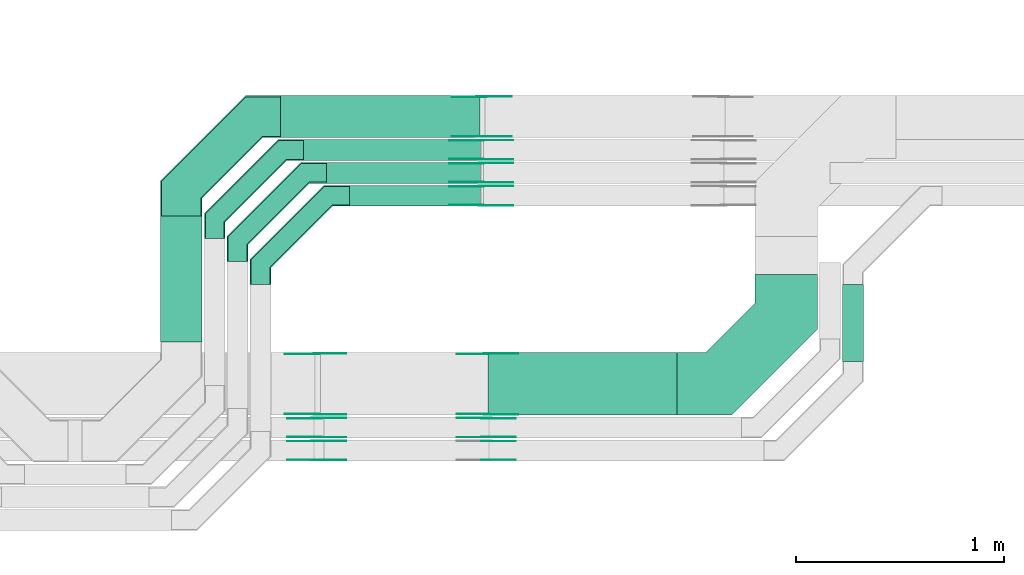
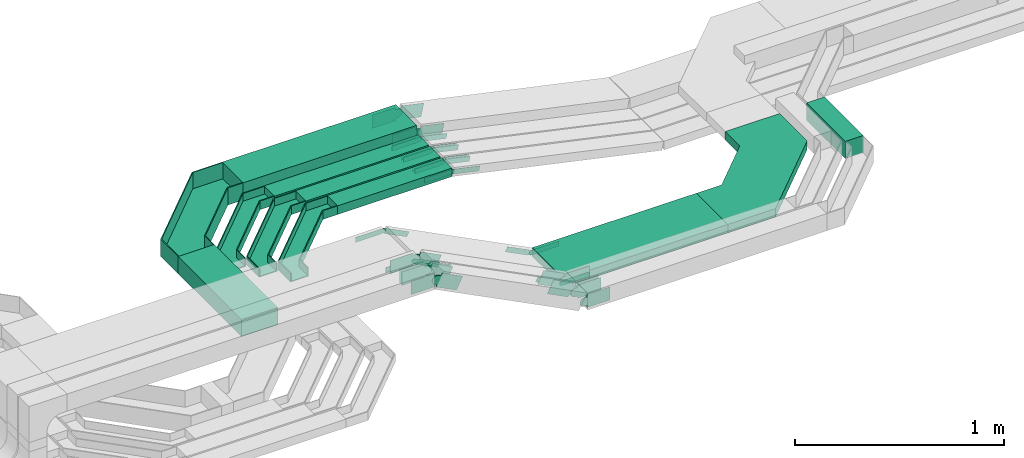
# One storey, part 15 of 33: 43 flow fittings, 7 flow segments.
"""IFC2X3 building model written with IfcOpenShell, lengths in millimetres."""

from ifc_helpers import new_model, entity, si_unit, converted_unit, derived_unit, direction, frame, frame_2d, origin, origin_2d_with_axis, place, context, subcontext, project, spatial, polyline, circle_curve, parameter, trimmed, segment, composite_curve, rectangle, outline, extrude, faceted_brep, source, transform, mapped, material, type_object, type_shapes, element, save


model = new_model("IFC2X3")

# Units and contexts
model_context = context("Model", 3, precision=0.01, world=origin(), true_north=direction((6.12303176911189e-17, 1.0)))
body_context = subcontext(model_context, "Body", "Model", "MODEL_VIEW")
ifc_project = project(units=[si_unit("LENGTHUNIT", "METRE", prefix="MILLI"), si_unit("AREAUNIT", "SQUARE_METRE"), si_unit("VOLUMEUNIT", "CUBIC_METRE"), converted_unit("PLANEANGLEUNIT", "DEGREE", entity("IfcRatioMeasure", 0.0174532925199433), si_unit("PLANEANGLEUNIT", "RADIAN"), dimensions=[0, 0, 0, 0, 0, 0, 0]), si_unit("MASSUNIT", "GRAM", prefix="KILO"), derived_unit("MASSDENSITYUNIT", [(si_unit("MASSUNIT", "GRAM", prefix="KILO"), 1), (si_unit("LENGTHUNIT", "METRE"), -3)]), derived_unit("MOMENTOFINERTIAUNIT", [(si_unit("LENGTHUNIT", "METRE"), 4)]), si_unit("TIMEUNIT", "SECOND"), si_unit("FREQUENCYUNIT", "HERTZ"), si_unit("THERMODYNAMICTEMPERATUREUNIT", "DEGREE_CELSIUS"), derived_unit("THERMALTRANSMITTANCEUNIT", [(si_unit("MASSUNIT", "GRAM", prefix="KILO"), 1), (si_unit("THERMODYNAMICTEMPERATUREUNIT", "KELVIN"), -1), (si_unit("TIMEUNIT", "SECOND"), -3)]), derived_unit("VOLUMETRICFLOWRATEUNIT", [(si_unit("LENGTHUNIT", "METRE"), 3), (si_unit("TIMEUNIT", "SECOND"), -1)]), derived_unit("MASSFLOWRATEUNIT", [(si_unit("MASSUNIT", "GRAM", prefix="KILO"), 1), (si_unit("TIMEUNIT", "SECOND"), -1)]), derived_unit("ROTATIONALFREQUENCYUNIT", [(si_unit("TIMEUNIT", "SECOND"), -1)]), si_unit("ELECTRICCURRENTUNIT", "AMPERE"), si_unit("ELECTRICVOLTAGEUNIT", "VOLT"), si_unit("POWERUNIT", "WATT"), si_unit("FORCEUNIT", "NEWTON", prefix="KILO"), si_unit("ILLUMINANCEUNIT", "LUX"), si_unit("LUMINOUSFLUXUNIT", "LUMEN"), si_unit("LUMINOUSINTENSITYUNIT", "CANDELA"), derived_unit("USERDEFINED", [(si_unit("MASSUNIT", "GRAM", prefix="KILO"), -1), (si_unit("LENGTHUNIT", "METRE"), -2), (si_unit("TIMEUNIT", "SECOND"), 3), (si_unit("LUMINOUSFLUXUNIT", "LUMEN"), 1)]), derived_unit("LINEARVELOCITYUNIT", [(si_unit("LENGTHUNIT", "METRE"), 1), (si_unit("TIMEUNIT", "SECOND"), -1)]), si_unit("PRESSUREUNIT", "PASCAL"), derived_unit("USERDEFINED", [(si_unit("LENGTHUNIT", "METRE"), -2), (si_unit("MASSUNIT", "GRAM", prefix="KILO"), 1), (si_unit("TIMEUNIT", "SECOND"), -2)]), derived_unit("LINEARFORCEUNIT", [(si_unit("MASSUNIT", "GRAM", prefix="KILO"), 1), (si_unit("LENGTHUNIT", "METRE"), 1), (si_unit("TIMEUNIT", "SECOND"), -2), (si_unit("LENGTHUNIT", "METRE"), -1)]), derived_unit("PLANARFORCEUNIT", [(si_unit("MASSUNIT", "GRAM", prefix="KILO"), 1), (si_unit("LENGTHUNIT", "METRE"), 1), (si_unit("TIMEUNIT", "SECOND"), -2), (si_unit("LENGTHUNIT", "METRE"), -2)])], contexts=[model_context])

# Site, building, storey
site_placement = place(None, frame((0.0, -0.00077364408347762, 0.0)))
site = spatial("IfcSite", under=ifc_project, at=site_placement, CompositionType="ELEMENT")
building_placement = place(site_placement, origin())
building = spatial("IfcBuilding", under=site, at=building_placement, CompositionType="ELEMENT")
storey_placement = place(building_placement, frame((0.0, 0.0, 8100.0)))
storey = spatial("IfcBuildingStorey", under=building, at=storey_placement, CompositionType="ELEMENT", Elevation=8100.0)

# Flow segments
cable_carrier_segment_type = type_object("IfcCableCarrierSegmentType", PredefinedType="CABLETRAYSEGMENT")
flow_segment_1_placement = place(storey_placement, frame((30990.7833235452, 8994.01799859663, 2800.0)))
element("IfcFlowSegment", 1, at=flow_segment_1_placement, inside=storey, type_object=cable_carrier_segment_type, context=body_context, shape_type="SweptSolid", body=[
    extrude(rectangle(XDim=604.980554870236, YDim=199.999999999998, at=frame_2d((-5.40012479177676e-13, -2.16715534406831e-12), x_axis=(1.0, 0.0))), frame((100.0, 302.490277435132, 0.0), z_axis=(0.0, 0.0, 1.0), x_axis=(0.0, 1.0, 0.0)), (0.0, 0.0, 1.0), 99.9999999999989),
])
flow_segment_2_placement = place(storey_placement, frame((31676.7833235452, 9864.9985534668, 2800.0)))
element("IfcFlowSegment", 2, at=flow_segment_2_placement, inside=storey, type_object=cable_carrier_segment_type, context=body_context, shape_type="SweptSolid", body=[
    extrude(rectangle(XDim=849.378940105925, YDim=99.9999999999989, at=origin_2d_with_axis()), frame((424.689470052967, 50.0, 0.0)), (0.0, 0.0, 1.0), 50.0000000000038),
])
flow_segment_3_placement = place(storey_placement, frame((31786.3066804005, 9754.99855346682, 2800.0)))
element("IfcFlowSegment", 3, at=flow_segment_3_placement, inside=storey, type_object=cable_carrier_segment_type, context=body_context, shape_type="SweptSolid", body=[
    extrude(rectangle(XDim=739.872366553705, YDim=99.9999999999989, at=origin_2d_with_axis()), frame((369.936183276852, 50.0, 0.0)), (0.0, 0.0, 1.0), 50.0000000000016),
])
flow_segment_4_placement = place(storey_placement, frame((31896.3066804005, 9644.99855346679, 2800.0)))
element("IfcFlowSegment", 4, at=flow_segment_4_placement, inside=storey, type_object=cable_carrier_segment_type, context=body_context, shape_type="SweptSolid", body=[
    extrude(rectangle(XDim=629.876149019233, YDim=100.000000000001, at=frame_2d((0.0, 5.43565192856477e-13), x_axis=(1.0, 0.0))), frame((314.938074509634, 50.0, 0.0)), (0.0, 0.0, 1.0), 50.0000000000016),
])
flow_segment_5_placement = place(storey_placement, frame((31566.7833235452, 9974.99855346669, 2800.0)))
element("IfcFlowSegment", 5, at=flow_segment_5_placement, inside=storey, type_object=cable_carrier_segment_type, context=body_context, shape_type="SweptSolid", body=[
    extrude(rectangle(XDim=956.723623030227, YDim=200.000000000002, at=frame_2d((2.18847162614111e-12, -1.08713038571295e-12), x_axis=(1.0, 0.0))), frame((478.361811515116, 100.0, 0.0)), (0.0, 0.0, 1.0), 99.9999999999968),
])
flow_segment_6_placement = place(storey_placement, frame((32562.9597702786, 8642.04668110939, 2750.017113393)))
element("IfcFlowSegment", 6, at=flow_segment_6_placement, inside=storey, type_object=cable_carrier_segment_type, context=body_context, shape_type="SweptSolid", body=[
    extrude(rectangle(XDim=905.362974416974, YDim=300.000000000001, at=frame_2d((0.0, 5.40012479177676e-13), x_axis=(1.0, 0.0))), frame((452.681487208496, 150.0, 0.0)), (0.0, 0.0, 1.0), 50.0000000000016),
])
flow_segment_7_placement = place(storey_placement, frame((34263.9176052606, 8898.45182054438, 2749.28135320931)))
element("IfcFlowSegment", 7, at=flow_segment_7_placement, inside=storey, type_object=cable_carrier_segment_type, context=body_context, shape_type="SweptSolid", body=[
    extrude(rectangle(XDim=370.546732922424, YDim=100.000000000003, at=frame_2d((0.0, 4.33431068813661e-12), x_axis=(1.0, 0.0))), frame((50.0, 185.273366461214, 0.0), z_axis=(0.0, 0.0, 1.0), x_axis=(0.0, 1.0, 0.0)), (0.0, 0.0, 1.0), 99.9999999999989),
])

# Flow fittings
ifc_material_1 = material(Name="G")
cable_carrier_fitting_type_1 = type_object("IfcCableCarrierFittingType", PredefinedType="NOTDEFINED", material=ifc_material_1)
shared_shape_1 = source(origin(), body_context, "Body", "SweptSolid", [
    extrude(outline(composite_curve([segment(trimmed(circle_curve(frame_2d((-44.5901162790698, 0.0), x_axis=(1.0, 0.0)), 12.5), [parameter(90.0000000000007)], [parameter(270.0)], True, "PARAMETER"), True, "CONTINUOUS"), segment(polyline([(-44.5901162790697, -12.5), (-33.0901162790698, -12.5)]), True, "CONTINUOUS"), segment(polyline([(-33.0901162790698, -12.5), (-31.2296511627907, -14.5)]), True, "CONTINUOUS"), segment(polyline([(-31.2296511627907, -14.5), (108.90988372093, -14.5)]), True, "CONTINUOUS"), segment(polyline([(108.90988372093, -14.5), (108.90988372093, 14.5)]), True, "CONTINUOUS"), segment(polyline([(108.90988372093, 14.5), (-31.2296511627907, 14.5)]), True, "CONTINUOUS"), segment(polyline([(-31.2296511627907, 14.5), (-33.0901162790698, 12.5)]), True, "CONTINUOUS"), segment(polyline([(-33.0901162790698, 12.5), (-44.5901162790699, 12.5)]), True, "CONTINUOUS")], self_intersect=False)), frame((44.5901162790698, 0.0, 0.0), z_axis=(0.0, 0.0, -1.0), x_axis=(1.0, 0.0, 0.0)), (0.0, 0.0, -1.0), 2.0),
])
type_shapes(cable_carrier_fitting_type_1, [shared_shape_1])
for number, where, z_axis, x_axis in (
    (8, (32530.3066804006, 9740.45855347711, 2825.0), (0.0, 1.0, 0.0), (0.977059422663225, 0.0, -0.212966862645354)),
    (9, (32530.3066804006, 9850.45855347702, 2825.0), (0.0, 1.0, 0.0), (0.977004473697579, 0.0, -0.21321880398998)),
    (10, (32530.3066804006, 9960.458553477, 2825.0), (0.0, 1.0, 0.0), (0.976759892794402, 0.0, -0.214336445403643)),
    (11, (32555.0055651353, 8646.58668109923, 2775.01711339303), (0.0, -1.0, 0.0), (1.0, 0.0, 0.0)),
    (12, (31739.4603210587, 8937.50668111956, 3190.01711365166), (0.0, 1.0, 0.0), (0.891245577778197, 0.0, -0.453521024971068)),
):
    element("IfcFlowFitting", number, at=place(storey_placement, frame(where, z_axis=z_axis, x_axis=x_axis)), inside=storey, type_object=cable_carrier_fitting_type_1, material=ifc_material_1, context=body_context, shape_type="MappedRepresentation", body=[
        mapped(shared_shape_1, transform((0.0, 0.0, 0.0), scale=1.0)),
    ])
cable_carrier_fitting_type_2 = type_object("IfcCableCarrierFittingType", PredefinedType="NOTDEFINED", material=ifc_material_1)
shared_shape_2 = source(origin(), body_context, "Body", "SweptSolid", [
    extrude(outline(composite_curve([segment(trimmed(circle_curve(frame_2d((-44.5901162790697, 0.0), x_axis=(1.0, 0.0)), 12.5), [parameter(90.0000000000007)], [parameter(270.0)], True, "PARAMETER"), True, "CONTINUOUS"), segment(polyline([(-44.5901162790697, -12.5), (-33.0901162790697, -12.5)]), True, "CONTINUOUS"), segment(polyline([(-33.0901162790697, -12.5), (-31.2296511627907, -14.5)]), True, "CONTINUOUS"), segment(polyline([(-31.2296511627907, -14.5), (108.90988372093, -14.5)]), True, "CONTINUOUS"), segment(polyline([(108.90988372093, -14.5), (108.90988372093, 14.5)]), True, "CONTINUOUS"), segment(polyline([(108.90988372093, 14.5), (-31.2296511627907, 14.5)]), True, "CONTINUOUS"), segment(polyline([(-31.2296511627907, 14.5), (-33.0901162790698, 12.5)]), True, "CONTINUOUS"), segment(polyline([(-33.0901162790698, 12.5), (-44.5901162790699, 12.5)]), True, "CONTINUOUS")], self_intersect=False)), frame((44.5901162790697, 0.0, 0.0)), (0.0, 0.0, 1.0), 2.0),
])
type_shapes(cable_carrier_fitting_type_2, [shared_shape_2])
for number, where, z_axis, x_axis in (
    (13, (32530.3066804006, 9649.53855345679, 2825.0), (0.0, -1.0, 0.0), (0.977059422663225, 0.0, -0.212966862645354)),
    (14, (32530.3066804006, 9759.53855345671, 2825.0), (0.0, -1.0, 0.0), (0.977004473697579, 0.0, -0.21321880398998)),
    (15, (32530.3066804006, 9869.53855345668, 2825.0), (0.0, -1.0, 0.0), (0.976759892794402, 0.0, -0.214336445403643)),
    (16, (32555.0055651353, 8937.50668111955, 2775.01711339303), (0.0, 1.0, 0.0), (1.0, 0.0, 0.0)),
    (17, (31739.4603210587, 8646.58668109924, 3190.01711365166), (0.0, -1.0, 0.0), (0.891245577778197, 0.0, -0.453521024971068)),
):
    element("IfcFlowFitting", number, at=place(storey_placement, frame(where, z_axis=z_axis, x_axis=x_axis)), inside=storey, type_object=cable_carrier_fitting_type_2, material=ifc_material_1, context=body_context, shape_type="MappedRepresentation", body=[
        mapped(shared_shape_2, transform((0.0, 0.0, 0.0), scale=1.0)),
    ])
cable_carrier_fitting_type_3 = type_object("IfcCableCarrierFittingType", PredefinedType="NOTDEFINED", material=ifc_material_1)
shared_shape_3 = source(origin(), body_context, "Body", "SweptSolid", [
    extrude(outline(composite_curve([segment(trimmed(circle_curve(frame_2d((-44.5901162790698, 0.0), x_axis=(1.0, 0.0)), 12.5), [parameter(90.0000000000007)], [parameter(270.0)], True, "PARAMETER"), True, "CONTINUOUS"), segment(polyline([(-44.5901162790697, -12.5), (-33.0901162790698, -12.5)]), True, "CONTINUOUS"), segment(polyline([(-33.0901162790698, -12.5), (-31.2296511627907, -14.5)]), True, "CONTINUOUS"), segment(polyline([(-31.2296511627907, -14.5), (108.90988372093, -14.5)]), True, "CONTINUOUS"), segment(polyline([(108.90988372093, -14.5), (108.90988372093, 14.5)]), True, "CONTINUOUS"), segment(polyline([(108.90988372093, 14.5), (-31.2296511627907, 14.5)]), True, "CONTINUOUS"), segment(polyline([(-31.2296511627907, 14.5), (-33.0901162790698, 12.5)]), True, "CONTINUOUS"), segment(polyline([(-33.0901162790698, 12.5), (-44.5901162790699, 12.5)]), True, "CONTINUOUS")], self_intersect=False)), frame((44.5901162790698, 0.0, 0.0), z_axis=(0.0, 0.0, -1.0), x_axis=(1.0, 0.0, 0.0)), (0.0, 0.0, -1.0), 2.0),
])
type_shapes(cable_carrier_fitting_type_3, [shared_shape_3])
for number, where, z_axis, x_axis in (
    (18, (32530.3066804006, 9651.53855345679, 2825.0), (0.0, -1.0, 0.0), (-1.0, 0.0, 0.0)),
    (19, (32530.3066804006, 9761.53855345671, 2825.0), (0.0, -1.0, 0.0), (-1.0, 0.0, 0.0)),
    (20, (32530.3066804006, 9871.53855345668, 2825.0), (0.0, -1.0, 0.0), (-1.0, 0.0, 0.0)),
    (21, (32555.0055651353, 8935.50668111955, 2775.01711339303), (0.0, 1.0, 0.0), (-0.891245577775967, 0.0, 0.453521024975451)),
    (22, (31739.4603210587, 8648.58668109924, 3190.01711365165), (0.0, -1.0, 0.0), (-1.0, 0.0, 0.0)),
):
    element("IfcFlowFitting", number, at=place(storey_placement, frame(where, z_axis=z_axis, x_axis=x_axis)), inside=storey, type_object=cable_carrier_fitting_type_3, material=ifc_material_1, context=body_context, shape_type="MappedRepresentation", body=[
        mapped(shared_shape_3, transform((0.0, 0.0, 0.0), scale=1.0)),
    ])
cable_carrier_fitting_type_4 = type_object("IfcCableCarrierFittingType", PredefinedType="NOTDEFINED", material=ifc_material_1)
shared_shape_4 = source(origin(), body_context, "Body", "SweptSolid", [
    extrude(outline(composite_curve([segment(trimmed(circle_curve(frame_2d((-44.5901162790697, 0.0), x_axis=(1.0, 0.0)), 12.5), [parameter(90.0000000000007)], [parameter(270.0)], True, "PARAMETER"), True, "CONTINUOUS"), segment(polyline([(-44.5901162790697, -12.5), (-33.0901162790697, -12.5)]), True, "CONTINUOUS"), segment(polyline([(-33.0901162790697, -12.5), (-31.2296511627907, -14.5)]), True, "CONTINUOUS"), segment(polyline([(-31.2296511627907, -14.5), (108.90988372093, -14.5)]), True, "CONTINUOUS"), segment(polyline([(108.90988372093, -14.5), (108.90988372093, 14.5)]), True, "CONTINUOUS"), segment(polyline([(108.90988372093, 14.5), (-31.2296511627907, 14.5)]), True, "CONTINUOUS"), segment(polyline([(-31.2296511627907, 14.5), (-33.0901162790698, 12.5)]), True, "CONTINUOUS"), segment(polyline([(-33.0901162790698, 12.5), (-44.5901162790699, 12.5)]), True, "CONTINUOUS")], self_intersect=False)), frame((44.5901162790697, 0.0, 0.0)), (0.0, 0.0, 1.0), 2.0),
])
type_shapes(cable_carrier_fitting_type_4, [shared_shape_4])
for number, where, z_axis, x_axis in (
    (23, (32530.3066804006, 9738.4585534771, 2825.0), (0.0, 1.0, 0.0), (-1.0, 0.0, 0.0)),
    (24, (32530.3066804006, 9848.45855347702, 2825.0), (0.0, 1.0, 0.0), (-1.0, 0.0, 0.0)),
    (25, (32530.3066804006, 9958.458553477, 2825.0), (0.0, 1.0, 0.0), (-1.0, 0.0, 0.0)),
    (26, (32555.0055651353, 8648.58668109923, 2775.01711339303), (0.0, -1.0, 0.0), (-0.891245577775967, 0.0, 0.453521024975451)),
    (27, (31739.4603210587, 8935.50668111956, 3190.01711365165), (0.0, 1.0, 0.0), (-1.0, 0.0, 0.0)),
):
    element("IfcFlowFitting", number, at=place(storey_placement, frame(where, z_axis=z_axis, x_axis=x_axis)), inside=storey, type_object=cable_carrier_fitting_type_4, material=ifc_material_1, context=body_context, shape_type="MappedRepresentation", body=[
        mapped(shared_shape_4, transform((0.0, 0.0, 0.0), scale=1.0)),
    ])
cable_carrier_fitting_type_5 = type_object("IfcCableCarrierFittingType", PredefinedType="NOTDEFINED", material=ifc_material_1)
shared_shape_5 = source(origin(), body_context, "Body", "SweptSolid", [
    extrude(outline(composite_curve([segment(trimmed(circle_curve(frame_2d((-41.4651162790697, 0.0), x_axis=(1.0, 0.0)), 25.0), [parameter(90.0000000000007)], [parameter(270.0)], True, "PARAMETER"), True, "CONTINUOUS"), segment(polyline([(-41.4651162790697, -25.0), (-29.9651162790697, -25.0)]), True, "CONTINUOUS"), segment(polyline([(-29.9651162790697, -25.0), (-28.1046511627907, -38.5)]), True, "CONTINUOUS"), segment(polyline([(-28.1046511627907, -38.5), (99.5348837209303, -38.5)]), True, "CONTINUOUS"), segment(polyline([(99.5348837209303, -38.5), (99.5348837209303, 38.5)]), True, "CONTINUOUS"), segment(polyline([(99.5348837209303, 38.5), (-28.1046511627907, 38.5)]), True, "CONTINUOUS"), segment(polyline([(-28.1046511627907, 38.5), (-29.9651162790697, 25.0)]), True, "CONTINUOUS"), segment(polyline([(-29.9651162790697, 25.0), (-41.46511627907, 25.0)]), True, "CONTINUOUS")], self_intersect=False)), frame((41.4651162790697, 0.0, 0.0), z_axis=(0.0, 0.0, -1.0), x_axis=(1.0, 0.0, 0.0)), (0.0, 0.0, -1.0), 2.0),
])
type_shapes(cable_carrier_fitting_type_5, [shared_shape_5])
for number, where, z_axis, x_axis in (
    (28, (32555.0055651355, 8627.91182055453, 2800.01096864734), (0.0, 1.0, 0.0), (-0.891242858773305, 0.0, 0.453526368236277)),
    (29, (31739.4603210587, 8517.91182055455, 3214.29820786538), (0.0, 1.0, 0.0), (0.891238132843699, 0.0, -0.45353565523041)),
    (30, (31739.4603210588, 8627.91182055453, 3215.01712441885), (0.0, 1.0, 0.0), (0.891242858773305, 0.0, -0.453526368236277)),
    (31, (32530.3066804006, 10170.4585534769, 2850.0), (0.0, 1.0, 0.0), (0.977192506439547, 0.0, -0.212355375157765)),
):
    element("IfcFlowFitting", number, at=place(storey_placement, frame(where, z_axis=z_axis, x_axis=x_axis)), inside=storey, type_object=cable_carrier_fitting_type_5, material=ifc_material_1, context=body_context, shape_type="MappedRepresentation", body=[
        mapped(shared_shape_5, transform((0.0, 0.0, 0.0), scale=1.0)),
    ])
cable_carrier_fitting_type_6 = type_object("IfcCableCarrierFittingType", PredefinedType="NOTDEFINED", material=ifc_material_1)
shared_shape_6 = source(origin(), body_context, "Body", "SweptSolid", [
    extrude(outline(composite_curve([segment(trimmed(circle_curve(frame_2d((-41.4651162790697, 0.0), x_axis=(1.0, 0.0)), 25.0), [parameter(90.0000000000007)], [parameter(270.0)], True, "PARAMETER"), True, "CONTINUOUS"), segment(polyline([(-41.4651162790697, -25.0), (-29.9651162790697, -25.0)]), True, "CONTINUOUS"), segment(polyline([(-29.9651162790697, -25.0), (-28.1046511627907, -38.5)]), True, "CONTINUOUS"), segment(polyline([(-28.1046511627907, -38.5), (99.5348837209303, -38.5)]), True, "CONTINUOUS"), segment(polyline([(99.5348837209303, -38.5), (99.5348837209303, 38.5)]), True, "CONTINUOUS"), segment(polyline([(99.5348837209303, 38.5), (-28.1046511627907, 38.5)]), True, "CONTINUOUS"), segment(polyline([(-28.1046511627907, 38.5), (-29.9651162790697, 25.0)]), True, "CONTINUOUS"), segment(polyline([(-29.9651162790697, 25.0), (-41.46511627907, 25.0)]), True, "CONTINUOUS")], self_intersect=False)), frame((41.4651162790697, 0.0, 0.0)), (0.0, 0.0, 1.0), 2.0),
])
type_shapes(cable_carrier_fitting_type_6, [shared_shape_6])
for number, where, z_axis, x_axis in (
    (32, (32555.0055651355, 8536.99182053421, 2800.01096864733), (0.0, -1.0, 0.0), (-0.891242858773305, 0.0, 0.453526368236277)),
    (33, (31739.4603210587, 8426.99182053423, 3214.29820786538), (0.0, -1.0, 0.0), (0.891238132843699, 0.0, -0.45353565523041)),
    (34, (31739.4603210588, 8536.99182053421, 3215.01712441885), (0.0, -1.0, 0.0), (0.891242858773305, 0.0, -0.453526368236277)),
    (35, (32530.3066804006, 9979.53855345654, 2850.0), (0.0, -1.0, 0.0), (0.977192506439547, 0.0, -0.212355375157765)),
):
    element("IfcFlowFitting", number, at=place(storey_placement, frame(where, z_axis=z_axis, x_axis=x_axis)), inside=storey, type_object=cable_carrier_fitting_type_6, material=ifc_material_1, context=body_context, shape_type="MappedRepresentation", body=[
        mapped(shared_shape_6, transform((0.0, 0.0, 0.0), scale=1.0)),
    ])
cable_carrier_fitting_type_7 = type_object("IfcCableCarrierFittingType", PredefinedType="NOTDEFINED", material=ifc_material_1)
shared_shape_7 = source(origin(), body_context, "Body", "SweptSolid", [
    extrude(outline(composite_curve([segment(trimmed(circle_curve(frame_2d((-41.4651162790697, 0.0), x_axis=(1.0, 0.0)), 25.0), [parameter(90.0000000000007)], [parameter(270.0)], True, "PARAMETER"), True, "CONTINUOUS"), segment(polyline([(-41.4651162790697, -25.0), (-29.9651162790697, -25.0)]), True, "CONTINUOUS"), segment(polyline([(-29.9651162790697, -25.0), (-28.1046511627907, -38.5)]), True, "CONTINUOUS"), segment(polyline([(-28.1046511627907, -38.5), (99.5348837209303, -38.5)]), True, "CONTINUOUS"), segment(polyline([(99.5348837209303, -38.5), (99.5348837209303, 38.5)]), True, "CONTINUOUS"), segment(polyline([(99.5348837209303, 38.5), (-28.1046511627907, 38.5)]), True, "CONTINUOUS"), segment(polyline([(-28.1046511627907, 38.5), (-29.9651162790697, 25.0)]), True, "CONTINUOUS"), segment(polyline([(-29.9651162790697, 25.0), (-41.46511627907, 25.0)]), True, "CONTINUOUS")], self_intersect=False)), frame((41.4651162790697, 0.0, 0.0), z_axis=(0.0, 0.0, -1.0), x_axis=(1.0, 0.0, 0.0)), (0.0, 0.0, -1.0), 2.0),
])
type_shapes(cable_carrier_fitting_type_7, [shared_shape_7])
for number, where, z_axis, x_axis in (
    (36, (32555.0055651355, 8428.99182053424, 2799.2813532093), (0.0, -1.0, 0.0), (1.0, 0.0, 0.0)),
    (37, (32555.0055651355, 8538.99182053421, 2800.01096864734), (0.0, -1.0, 0.0), (1.0, 0.0, 0.0)),
    (38, (31739.4603210587, 8428.99182053423, 3214.29820786538), (0.0, -1.0, 0.0), (-1.0, 0.0, 0.0)),
    (39, (31739.4603210589, 8538.99182053421, 3215.01712441885), (0.0, -1.0, 0.0), (-1.0, 0.0, 0.0)),
    (40, (32530.3066804007, 9981.53855345654, 2850.0), (0.0, -1.0, 0.0), (-1.0, 0.0, 0.0)),
):
    element("IfcFlowFitting", number, at=place(storey_placement, frame(where, z_axis=z_axis, x_axis=x_axis)), inside=storey, type_object=cable_carrier_fitting_type_7, material=ifc_material_1, context=body_context, shape_type="MappedRepresentation", body=[
        mapped(shared_shape_7, transform((0.0, 0.0, 0.0), scale=1.0)),
    ])
cable_carrier_fitting_type_8 = type_object("IfcCableCarrierFittingType", PredefinedType="NOTDEFINED", material=ifc_material_1)
shared_shape_8 = source(origin(), body_context, "Body", "SweptSolid", [
    extrude(outline(composite_curve([segment(trimmed(circle_curve(frame_2d((-41.4651162790697, 0.0), x_axis=(1.0, 0.0)), 25.0), [parameter(90.0000000000007)], [parameter(270.0)], True, "PARAMETER"), True, "CONTINUOUS"), segment(polyline([(-41.4651162790697, -25.0), (-29.9651162790697, -25.0)]), True, "CONTINUOUS"), segment(polyline([(-29.9651162790697, -25.0), (-28.1046511627907, -38.5)]), True, "CONTINUOUS"), segment(polyline([(-28.1046511627907, -38.5), (99.5348837209303, -38.5)]), True, "CONTINUOUS"), segment(polyline([(99.5348837209303, -38.5), (99.5348837209303, 38.5)]), True, "CONTINUOUS"), segment(polyline([(99.5348837209303, 38.5), (-28.1046511627907, 38.5)]), True, "CONTINUOUS"), segment(polyline([(-28.1046511627907, 38.5), (-29.9651162790697, 25.0)]), True, "CONTINUOUS"), segment(polyline([(-29.9651162790697, 25.0), (-41.46511627907, 25.0)]), True, "CONTINUOUS")], self_intersect=False)), frame((41.4651162790697, 0.0, 0.0)), (0.0, 0.0, 1.0), 2.0),
])
type_shapes(cable_carrier_fitting_type_8, [shared_shape_8])
for number, where, z_axis, x_axis in (
    (41, (32555.0055651355, 8515.91182055455, 2799.2813532093), (0.0, 1.0, 0.0), (1.0, 0.0, 0.0)),
    (42, (32555.0055651355, 8625.91182055453, 2800.01096864734), (0.0, 1.0, 0.0), (1.0, 0.0, 0.0)),
    (43, (31739.4603210587, 8515.91182055455, 3214.29820786538), (0.0, 1.0, 0.0), (-1.0, 0.0, 0.0)),
    (44, (31739.4603210589, 8625.91182055453, 3215.01712441885), (0.0, 1.0, 0.0), (-1.0, 0.0, 0.0)),
    (45, (32530.3066804007, 10168.4585534769, 2850.0), (0.0, 1.0, 0.0), (-1.0, 0.0, 0.0)),
):
    element("IfcFlowFitting", number, at=place(storey_placement, frame(where, z_axis=z_axis, x_axis=x_axis)), inside=storey, type_object=cable_carrier_fitting_type_8, material=ifc_material_1, context=body_context, shape_type="MappedRepresentation", body=[
        mapped(shared_shape_8, transform((0.0, 0.0, 0.0), scale=1.0)),
    ])
ifc_material_2 = material()
cable_carrier_fitting_type_9 = type_object("IfcCableCarrierFittingType", Name="470_DKC_G5_Sheet horizontal bend:-", PredefinedType="NOTDEFINED", material=ifc_material_2)
shared_shape_9 = source(origin(), body_context, "Body", "Brep", [
    faceted_brep([(-476.0, -100.0, -50.0), (-476.0, -100.0, 50.0), (-476.0, -95.0, 50.0), (-476.0, -95.0, -45.0), (-476.0, 95.0, -45.0), (-476.0, 95.0, 50.0), (-476.0, 100.0, 50.0), (-476.0, 100.0, -50.0), (100.0, 476.0, -50.0), (-100.0, 476.0, -50.0), (-100.0, 476.0, 50.0), (-95.0, 476.0, 50.0), (-95.0, 476.0, -45.0), (95.0, 476.0, -45.0), (95.0, 476.0, 50.0), (100.0, 476.0, 50.0), (-308.578643762682, -100.0, -50.0), (-308.578643762682, -100.0, 50.0), (100.0, 308.578643762679, 50.0), (95.0, 310.649711574545, 50.0), (-310.649711574548, -95.0, 50.0), (-310.649711574548, -95.0, -45.0), (95.0, 310.649711574545, -45.0), (-95.0, 389.350288425433, -45.0), (-389.350288425436, 95.0, -45.0), (-389.350288425436, 95.0, 50.0), (-95.0, 389.350288425433, 50.0), (-100.0, 391.421356237299, 50.0), (-391.421356237301, 100.0, 50.0), (-391.421356237301, 100.0, -50.0), (-100.0, 391.421356237298, -50.0), (100.0, 308.57864376268, -50.0)], [[[0, 1, 2, 3, 4, 5, 6, 7]], [[8, 9, 10, 11, 12, 13, 14, 15]], [[1, 0, 16, 17]], [[2, 1, 17, 18, 15, 14, 19, 20]], [[3, 2, 20, 21]], [[4, 3, 21, 22, 13, 12, 23, 24]], [[5, 4, 24, 25]], [[6, 5, 25, 26, 11, 10, 27, 28]], [[7, 6, 28, 29]], [[0, 7, 29, 30, 9, 8, 31, 16]], [[17, 16, 31, 18]], [[21, 20, 19, 22]], [[25, 24, 23, 26]], [[29, 28, 27, 30]], [[18, 31, 8, 15]], [[22, 19, 14, 13]], [[26, 23, 12, 11]], [[30, 27, 10, 9]]]),
])
type_shapes(cable_carrier_fitting_type_9, [shared_shape_9])
flow_fitting_1_placement = place(storey_placement, frame((31090.7833235452, 10074.9985534669, 2850.0), z_axis=(0.0, 0.0, 1.0), x_axis=(-1.0, 0.0, 0.0)))
element("IfcFlowFitting", 46, at=flow_fitting_1_placement, inside=storey, type_object=cable_carrier_fitting_type_9, material=ifc_material_2, Name="470_DKC_G5_Sheet horizontal bend:-", ObjectType="470_DKC_G5_Sheet horizontal bend:-", context=body_context, shape_type="MappedRepresentation", body=[
    mapped(shared_shape_9, transform((0.0, 0.0, 0.0), scale=1.0)),
])
cable_carrier_fitting_type_10 = type_object("IfcCableCarrierFittingType", Name="470_DKC_G5_Sheet horizontal bend:-", PredefinedType="NOTDEFINED", material=ifc_material_2)
shared_shape_10 = source(origin(), body_context, "Body", "Brep", [
    faceted_brep([(-426.0, -50.0, -25.0), (-426.0, -50.0, 25.0), (-426.0, -45.0, 25.0), (-426.0, -45.0, -20.0), (-426.0, 45.0, -20.0), (-426.0, 45.0, 25.0), (-426.0, 50.0, 25.0), (-426.0, 50.0, -25.0), (50.0, 426.0, -25.0), (-50.0, 426.0, -25.0), (-50.0, 426.0, 25.0), (-45.0, 426.0, 25.0), (-45.0, 426.0, -20.0), (45.0, 426.0, -20.0), (45.0, 426.0, 25.0), (50.0, 426.0, 25.0), (-304.289321881337, -50.0, -25.0), (-304.289321881337, -50.0, 25.0), (50.0, 304.289321881334, 25.0), (45.0, 306.3603896932, 25.0), (-306.360389693203, -45.0, 25.0), (-306.360389693203, -45.0, -20.0), (45.0, 306.3603896932, -20.0), (-45.0, 343.639610306778, -20.0), (-343.639610306781, 45.0, -20.0), (-343.639610306781, 45.0, 25.0), (-45.0, 343.639610306778, 25.0), (-50.0, 345.710678118644, 25.0), (-345.710678118647, 50.0, 25.0), (-345.710678118647, 50.0, -25.0), (-50.0, 345.710678118644, -25.0), (50.0, 304.289321881334, -25.0)], [[[0, 1, 2, 3, 4, 5, 6, 7]], [[8, 9, 10, 11, 12, 13, 14, 15]], [[1, 0, 16, 17]], [[2, 1, 17, 18, 15, 14, 19, 20]], [[3, 2, 20, 21]], [[4, 3, 21, 22, 13, 12, 23, 24]], [[5, 4, 24, 25]], [[6, 5, 25, 26, 11, 10, 27, 28]], [[7, 6, 28, 29]], [[0, 7, 29, 30, 9, 8, 31, 16]], [[17, 16, 31, 18]], [[21, 20, 19, 22]], [[25, 24, 23, 26]], [[29, 28, 27, 30]], [[18, 31, 8, 15]], [[22, 19, 14, 13]], [[26, 23, 12, 11]], [[30, 27, 10, 9]]]),
])
type_shapes(cable_carrier_fitting_type_10, [shared_shape_10])
for number, where, z_axis, x_axis, name in (
    (47, (31250.7833235452, 9914.99855346678, 2825.0), (0.0, 0.0, 1.0), (-1.0, 0.0, 0.0), "470_DKC_G5_Sheet horizontal bend:-"),
    (48, (31360.3066804005, 9804.9985534668, 2825.0), (0.0, 0.0, 1.0), (-1.0, 0.0, 0.0), "470_DKC_G5_Sheet horizontal bend:-"),
    (49, (31470.3066804005, 9694.99855346677, 2825.0), (0.0, 0.0, 1.0), (-1.0, 0.0, 0.0), "470_DKC_G5_Sheet horizontal bend:-"),
):
    element("IfcFlowFitting", number, at=place(storey_placement, frame(where, z_axis=z_axis, x_axis=x_axis)), inside=storey, type_object=cable_carrier_fitting_type_10, material=ifc_material_2, Name=name, ObjectType="470_DKC_G5_Sheet horizontal bend:-", context=body_context, shape_type="MappedRepresentation", body=[
        mapped(shared_shape_10, transform((0.0, 0.0, 0.0), scale=1.0)),
    ])
cable_carrier_fitting_type_11 = type_object("IfcCableCarrierFittingType", Name="470_DKC_G5_Sheet horizontal bend:-", PredefinedType="NOTDEFINED", material=ifc_material_2)
shared_shape_11 = source(origin(), body_context, "Body", "SweptSolid", [
    extrude(outline(polyline([(-313.25, -362.749999999999), (-50.1179656440353, -362.749999999999), (362.749999999999, 50.1179656440352), (362.75, 313.249999999999), (62.7500000000001, 313.25), (62.7499999999997, 174.382034355964), (-174.382034355964, -62.7499999999997), (-313.25, -62.7499999999995), (-313.25, -362.749999999999)])), frame((-212.749999999993, 212.749999999989, -25.0)), (0.0, 0.0, 1.0), 50.0000000000003),
])
type_shapes(cable_carrier_fitting_type_11, [shared_shape_11])
flow_fitting_2_placement = place(storey_placement, frame((33994.3227446956, 8792.04668110943, 2775.0171133931)))
element("IfcFlowFitting", 50, at=flow_fitting_2_placement, inside=storey, type_object=cable_carrier_fitting_type_11, material=ifc_material_2, Name="470_DKC_G5_Sheet horizontal bend:-", ObjectType="470_DKC_G5_Sheet horizontal bend:-", context=body_context, shape_type="MappedRepresentation", body=[
    mapped(shared_shape_11, transform((0.0, 0.0, 0.0), scale=1.0)),
])

save(model, "model.ifc")
